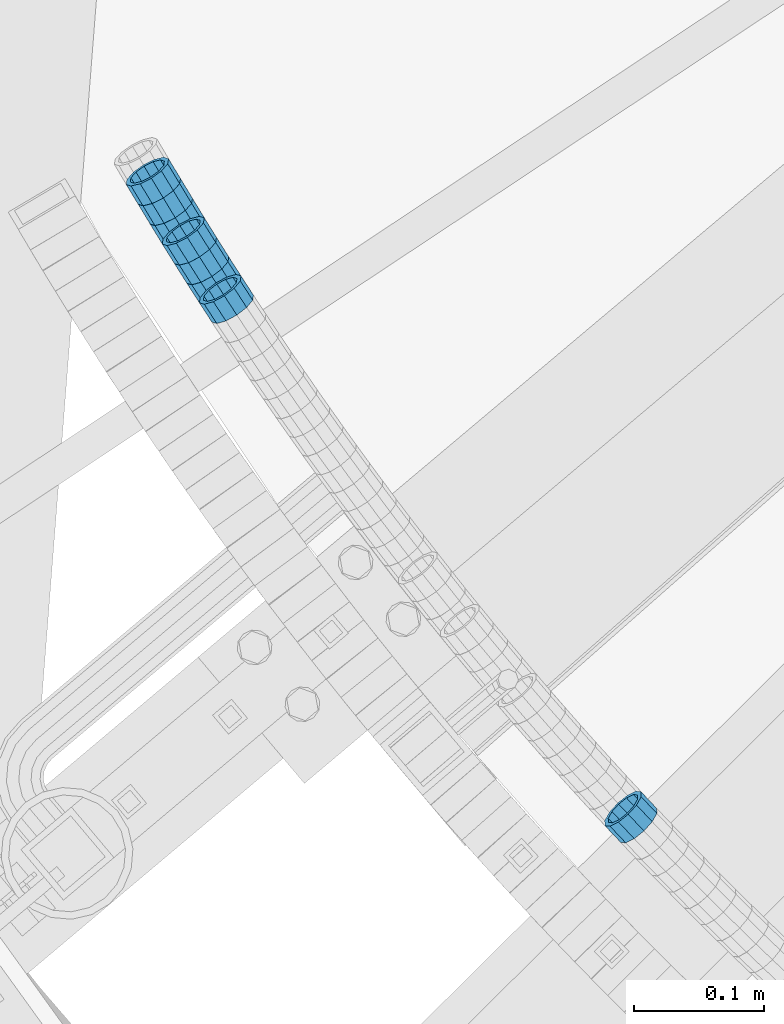
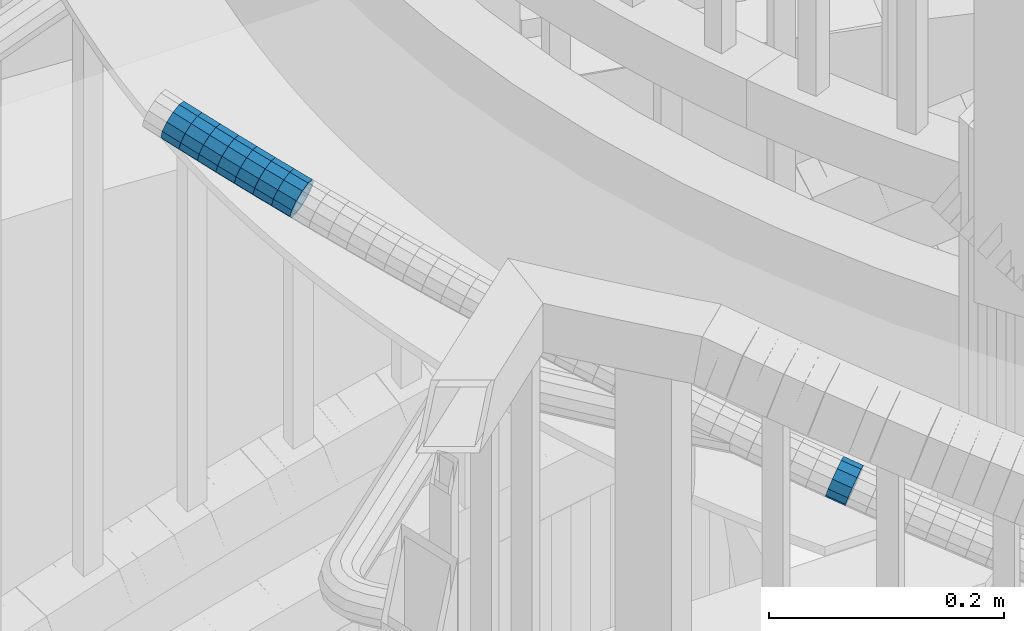
# One storey, part 655 of 975: 8 beams.
"""IFC2X3 building model written with IfcOpenShell, lengths in millimetres."""

from ifc_helpers import new_model, si_unit, frame, origin_with_axes, place, context, subcontext, project, spatial, faceted_brep, material, type_object, element, save


model = new_model("IFC2X3")

# Units and contexts
model_context = context("Model", 3, precision=1e-05, world=origin_with_axes())
body_context = subcontext(model_context, "Body", "Model", "MODEL_VIEW")
ifc_project = project(units=[si_unit("LENGTHUNIT", "METRE", prefix="MILLI"), si_unit("AREAUNIT", "SQUARE_METRE"), si_unit("VOLUMEUNIT", "CUBIC_METRE"), si_unit("MASSUNIT", "GRAM", prefix="KILO"), si_unit("TIMEUNIT", "SECOND"), si_unit("PLANEANGLEUNIT", "RADIAN"), si_unit("SOLIDANGLEUNIT", "STERADIAN"), si_unit("THERMODYNAMICTEMPERATUREUNIT", "DEGREE_CELSIUS"), si_unit("LUMINOUSINTENSITYUNIT", "LUMEN")], contexts=[model_context])

# Site, building, storey
site_placement = place(None, origin_with_axes())
site = spatial("IfcSite", under=ifc_project, at=site_placement, CompositionType="ELEMENT")
building_placement = place(site_placement, origin_with_axes())
building = spatial("IfcBuilding", under=site, at=building_placement, Name="Undefined", CompositionType="ELEMENT")
storey_placement = place(building_placement, origin_with_axes())
storey = spatial("IfcBuildingStorey", under=building, at=storey_placement, Name="Undefined", CompositionType="ELEMENT", Elevation=0.0)

# Beams
ifc_material = material()
beam_type = type_object("IfcBeamType", PredefinedType="NOTDEFINED")
beam_1_placement = place(storey_placement, frame((32387.4586977455, 1899.99917877906, 5122.80302633104), z_axis=(0.838961287171916, 0.544191104876625, -6.47896740701979e-11), x_axis=(0.516966515925029, -0.796990045884351, -0.312333936954659)))
element("IfcBeam", 1, at=beam_1_placement, inside=storey, type_object=beam_type, material=ifc_material, Name="WALL", context=body_context, shape_type="Brep", body=[
    faceted_brep([(-2.1246523829177e-07, -15.367000000002, 0.0), (-1.83998054126278e-07, -13.3082123799541, 7.68350000000009), (18.5698680663245, -13.3082123799541, 7.68350000001374), (18.569868066319, -15.3669999999947, 7.27595761418343e-12), (-1.06232619145885e-07, -7.68349999999919, 13.3082123799559), (18.5698680663281, -7.68350000000282, 13.3082123799759), (-3.63797880709171e-12, 3.63797880709171e-12, 15.3670000000002), (18.5698680663318, -3.63797880709171e-12, 15.3670000000275), (1.06225343188271e-07, 7.68350000000646, 13.3082123799559), (18.5698680663354, 7.68349999999555, 13.3082123799904), (1.8399441614747e-07, 13.308212379965, 7.68350000000009), (18.5698680663409, 13.3082123799522, 7.68350000003193), (2.12461600312963e-07, 15.3670000000093, 0.0), (18.569868066339, 15.3669999999966, 3.63797880709171e-11), (1.8399441614747e-07, 13.308212379965, -7.68350000000009), (18.5698680663336, 13.3082123799541, -7.68349999997008), (1.06225343188271e-07, 7.68350000000646, -13.3082123799559), (18.5698680663281, 7.68350000000282, -13.3082123799322), (-3.63797880709171e-12, 3.63797880709171e-12, -15.3670000000002), (18.5698680663263, 7.27595761418343e-12, -15.3669999999838), (-1.06232619145885e-07, -7.68349999999919, -13.3082123799559), (18.569868066319, -7.68349999999191, -13.3082123799468), (-1.83998054126278e-07, -13.3082123799541, -7.68350000000009), (18.5698680663172, -13.3082123799486, -7.68349999998827), (-2.63386027654633e-07, -19.0500000000029, 0.0), (-2.28097633225843e-07, -16.4977839420972, -9.52499999999964), (18.5698680663154, -16.4977839420862, -9.52499999999782), (18.5698680663154, -19.0499999999956, 7.27595761418343e-12), (-1.31691194837913e-07, -9.52500000000146, -16.4977839420935), (18.569868066319, -9.52499999999054, -16.4977839420862), (-3.63797880709171e-12, 3.63797880709171e-12, -19.0500000000002), (18.5698680663245, 7.27595761418343e-12, -19.0499999999847), (1.31687556859106e-07, 9.52500000000509, -16.4977839420935), (18.5698680663299, 9.52500000000509, -16.4977839420717), (2.28097633225843e-07, 16.4977839421044, -9.52499999999964), (18.5698680663372, 16.4977839420935, -9.52499999996871), (2.63382389675826e-07, 19.0500000000138, 0.0), (18.5698680663427, 19.0499999999956, 3.63797880709171e-11), (2.28097633225843e-07, 16.4977839421044, 9.52499999999964), (18.5698680663427, 16.4977839420899, 9.52500000004147), (1.31687556859106e-07, 9.52500000000509, 16.4977839420935), (18.569868066339, 9.52499999999418, 16.4977839421299), (-3.63797880709171e-12, 3.63797880709171e-12, 19.0500000000002), (18.5698680663336, -5.45696821063757e-12, 19.0500000000284), (-1.31691194837913e-07, -9.52500000000146, 16.4977839420935), (18.5698680663281, -9.52500000000146, 16.4977839421117), (-2.28097633225843e-07, -16.4977839420972, 9.52499999999964), (18.5698680663209, -16.4977839420917, 9.52500000001237)], [[[0, 1, 2, 3]], [[1, 4, 5, 2]], [[4, 6, 7, 5]], [[6, 8, 9, 7]], [[8, 10, 11, 9]], [[10, 12, 13, 11]], [[12, 14, 15, 13]], [[14, 16, 17, 15]], [[16, 18, 19, 17]], [[18, 20, 21, 19]], [[20, 22, 23, 21]], [[22, 0, 3, 23]], [[24, 25, 26, 27]], [[25, 28, 29, 26]], [[28, 30, 31, 29]], [[30, 32, 33, 31]], [[32, 34, 35, 33]], [[34, 36, 37, 35]], [[36, 38, 39, 37]], [[38, 40, 41, 39]], [[40, 42, 43, 41]], [[42, 44, 45, 43]], [[44, 46, 47, 45]], [[46, 24, 27, 47]], [[29, 31, 33, 35, 37, 39, 41, 43, 45, 47, 27, 26], [5, 7, 9, 11, 13, 15, 17, 19, 21, 23, 3, 2]], [[46, 44, 42, 40, 38, 36, 34, 32, 30, 28, 25, 24], [22, 20, 18, 16, 14, 12, 10, 8, 6, 4, 1, 0]]]),
])
beam_2_placement = place(storey_placement, frame((32368.4316061719, 1929.90477199626, 5134.3916756301), z_axis=(0.844819075603214, 0.535052081107, 9.88802639767529e-11), x_axis=(0.508603499889652, -0.803058157825771, -0.310515820932648)))
element("IfcBeam", 2, at=beam_2_placement, inside=storey, type_object=beam_type, material=ifc_material, Name="WALL", context=body_context, shape_type="Brep", body=[
    faceted_brep([(-2.1246523829177e-07, -15.367000000002, 0.0), (-1.83998054126278e-07, -13.3082123799541, 7.68350000000009), (18.6785973777551, -13.3082123799559, 7.68350000000282), (18.6785973777623, -15.3670000000002, 1.09139364212751e-11), (-1.06232619145885e-07, -7.68349999999919, 13.3082123799559), (18.6785973777532, -7.68350000000282, 13.3082123799541), (-3.63797880709171e-12, 3.63797880709171e-12, 15.3670000000002), (18.6785973777514, 0.0, 15.3669999999947), (1.06225343188271e-07, 7.68350000000646, 13.3082123799559), (18.678597377746, 7.68349999999919, 13.3082123799468), (1.8399441614747e-07, 13.308212379965, 7.68350000000009), (18.6785973777496, 13.3082123799541, 7.68349999999191), (2.12461600312963e-07, 15.3670000000093, 0.0), (18.6785973777514, 15.3670000000002, -3.63797880709171e-12), (1.8399441614747e-07, 13.308212379965, -7.68350000000009), (18.6785973777551, 13.3082123799577, -7.68349999999919), (1.06225343188271e-07, 7.68350000000646, -13.3082123799559), (18.6785973777605, 7.683500000001, -13.3082123799504), (-3.63797880709171e-12, 3.63797880709171e-12, -15.3670000000002), (18.6785973777642, 1.81898940354586e-12, -15.3669999999875), (-1.06232619145885e-07, -7.68349999999919, -13.3082123799559), (18.678597377766, -7.68349999999919, -13.3082123799431), (-1.83998054126278e-07, -13.3082123799541, -7.68350000000009), (18.6785973777605, -13.3082123799541, -7.68349999998827), (-2.63386027654633e-07, -19.0500000000029, 0.0), (-2.28097633225843e-07, -16.4977839420972, -9.52499999999964), (18.678597377766, -16.4977839420935, -9.52499999998327), (18.6785973777605, -19.0499999999993, 1.45519152283669e-11), (-1.31691194837913e-07, -9.52500000000146, -16.4977839420935), (18.6785973777678, -9.52499999999782, -16.497783942079), (-3.63797880709171e-12, 3.63797880709171e-12, -19.0500000000002), (18.678597377766, 3.63797880709171e-12, -19.0499999999884), (1.31687556859106e-07, 9.52500000000509, -16.4977839420935), (18.6785973777623, 9.52500000000146, -16.4977839420862), (2.28097633225843e-07, 16.4977839421044, -9.52499999999964), (18.6785973777551, 16.4977839420935, -9.52499999999782), (2.63382389675826e-07, 19.0500000000138, 0.0), (18.6785973777496, 19.0499999999993, -7.27595761418343e-12), (2.28097633225843e-07, 16.4977839421044, 9.52499999999964), (18.6785973777478, 16.4977839420935, 9.52499999999054), (1.31687556859106e-07, 9.52500000000509, 16.4977839420935), (18.678597377746, 9.52499999999782, 16.4977839420862), (-3.63797880709171e-12, 3.63797880709171e-12, 19.0500000000002), (18.6785973777442, -1.81898940354586e-12, 19.049999999992), (-1.31691194837913e-07, -9.52500000000146, 16.4977839420935), (18.6785973777514, -9.52500000000146, 16.4977839420972), (-2.28097633225843e-07, -16.4977839420972, 9.52499999999964), (18.6785973777551, -16.4977839420935, 9.52500000000509)], [[[0, 1, 2, 3]], [[1, 4, 5, 2]], [[4, 6, 7, 5]], [[6, 8, 9, 7]], [[8, 10, 11, 9]], [[10, 12, 13, 11]], [[12, 14, 15, 13]], [[14, 16, 17, 15]], [[16, 18, 19, 17]], [[18, 20, 21, 19]], [[20, 22, 23, 21]], [[22, 0, 3, 23]], [[24, 25, 26, 27]], [[25, 28, 29, 26]], [[28, 30, 31, 29]], [[30, 32, 33, 31]], [[32, 34, 35, 33]], [[34, 36, 37, 35]], [[36, 38, 39, 37]], [[38, 40, 41, 39]], [[40, 42, 43, 41]], [[42, 44, 45, 43]], [[44, 46, 47, 45]], [[46, 24, 27, 47]], [[29, 31, 33, 35, 37, 39, 41, 43, 45, 47, 27, 26], [5, 7, 9, 11, 13, 15, 17, 19, 21, 23, 3, 2]], [[46, 44, 42, 40, 38, 36, 34, 32, 30, 28, 25, 24], [22, 20, 18, 16, 14, 12, 10, 8, 6, 4, 1, 0]]]),
])
beam_3_placement = place(storey_placement, frame((32331.3879521192, 1990.64344126939, 5157.72073807088), z_axis=(0.85550007890286, 0.517802679596389, 1.8612809071783e-10), x_axis=(0.491416813934311, -0.811906039891549, -0.315147738957896)))
element("IfcBeam", 3, at=beam_3_placement, inside=storey, type_object=beam_type, material=ifc_material, Name="WALL", context=body_context, shape_type="Brep", body=[
    faceted_brep([(-2.1246523829177e-07, -15.367000000002, 0.0), (-1.83998054126278e-07, -13.3082123799541, 7.68350000000009), (18.7213781543887, -13.3082123799431, 7.68349999997372), (18.7213781543924, -15.3669999999856, -2.18278728425503e-11), (-1.06232619145885e-07, -7.68349999999919, 13.3082123799559), (18.7213781543869, -7.68349999999009, 13.308212379925), (-3.63797880709171e-12, 3.63797880709171e-12, 15.3670000000002), (18.7213781543869, 9.09494701772928e-12, 15.3669999999693), (1.06225343188271e-07, 7.68350000000646, 13.3082123799559), (18.7213781543905, 7.68350000000828, 13.3082123799286), (1.8399441614747e-07, 13.308212379965, 7.68350000000009), (18.7213781543942, 13.3082123799632, 7.683499999981), (2.12461600312963e-07, 15.3670000000093, 0.0), (18.7213781543978, 15.3670000000111, -1.81898940354586e-11), (1.8399441614747e-07, 13.308212379965, -7.68350000000009), (18.7213781544015, 13.3082123799668, -7.68350000000646), (1.06225343188271e-07, 7.68350000000646, -13.3082123799559), (18.7213781544033, 7.68350000001192, -13.3082123799613), (-3.63797880709171e-12, 3.63797880709171e-12, -15.3670000000002), (18.7213781544015, 1.63709046319127e-11, -15.3670000000093), (-1.06232619145885e-07, -7.68349999999919, -13.3082123799559), (18.7213781544015, -7.68349999998645, -13.308212379965), (-1.83998054126278e-07, -13.3082123799541, -7.68350000000009), (18.7213781543942, -13.3082123799413, -7.68350000001374), (-2.63386027654633e-07, -19.0500000000029, 0.0), (-2.28097633225843e-07, -16.4977839420972, -9.52499999999964), (18.721378154396, -16.4977839420771, -9.52500000001237), (18.7213781543905, -19.0499999999865, -2.18278728425503e-11), (-1.31691194837913e-07, -9.52500000000146, -16.4977839420935), (18.7213781544015, -9.52499999998508, -16.4977839421008), (-3.63797880709171e-12, 3.63797880709171e-12, -19.0500000000002), (18.7213781544033, 1.45519152283669e-11, -19.0500000000065), (1.31687556859106e-07, 9.52500000000509, -16.4977839420935), (18.7213781544051, 9.52500000001419, -16.4977839420935), (2.28097633225843e-07, 16.4977839421044, -9.52499999999964), (18.7213781544033, 16.4977839421063, -9.52500000000873), (2.63382389675826e-07, 19.0500000000138, 0.0), (18.7213781543978, 19.0500000000102, -1.45519152283669e-11), (2.28097633225843e-07, 16.4977839421044, 9.52499999999964), (18.7213781543942, 16.4977839421026, 9.52499999997599), (1.31687556859106e-07, 9.52500000000509, 16.4977839420935), (18.7213781543887, 9.52500000000691, 16.4977839420644), (-3.63797880709171e-12, 3.63797880709171e-12, 19.0500000000002), (18.7213781543833, 9.09494701772928e-12, 19.0499999999665), (-1.31691194837913e-07, -9.52500000000146, 16.4977839420935), (18.7213781543851, -9.52499999998872, 16.4977839420644), (-2.28097633225843e-07, -16.4977839420972, 9.52499999999964), (18.7213781543887, -16.4977839420808, 9.52499999997235)], [[[0, 1, 2, 3]], [[1, 4, 5, 2]], [[4, 6, 7, 5]], [[6, 8, 9, 7]], [[8, 10, 11, 9]], [[10, 12, 13, 11]], [[12, 14, 15, 13]], [[14, 16, 17, 15]], [[16, 18, 19, 17]], [[18, 20, 21, 19]], [[20, 22, 23, 21]], [[22, 0, 3, 23]], [[24, 25, 26, 27]], [[25, 28, 29, 26]], [[28, 30, 31, 29]], [[30, 32, 33, 31]], [[32, 34, 35, 33]], [[34, 36, 37, 35]], [[36, 38, 39, 37]], [[38, 40, 41, 39]], [[40, 42, 43, 41]], [[42, 44, 45, 43]], [[44, 46, 47, 45]], [[46, 24, 27, 47]], [[29, 31, 33, 35, 37, 39, 41, 43, 45, 47, 27, 26], [5, 7, 9, 11, 13, 15, 17, 19, 21, 23, 3, 2]], [[46, 44, 42, 40, 38, 36, 34, 32, 30, 28, 25, 24], [22, 20, 18, 16, 14, 12, 10, 8, 6, 4, 1, 0]]]),
])
beam_4_placement = place(storey_placement, frame((32340.6355277965, 1975.36483797635, 5151.79048636171), z_axis=(0.85550007890286, 0.517802679596389, 1.8612809071783e-10), x_axis=(0.492239092983619, -0.813264587972886, -0.310324644989658)))
element("IfcBeam", 4, at=beam_4_placement, inside=storey, type_object=beam_type, material=ifc_material, Name="WALL", context=body_context, shape_type="Brep", body=[
    faceted_brep([(-2.1246523829177e-07, -15.367000000002, 0.0), (-1.83998054126278e-07, -13.3082123799541, 7.68350000000009), (18.6901043335838, -13.3082123799413, 7.68349999999555), (18.6901043335874, -15.3669999999875, 3.63797880709171e-12), (-1.06232619145885e-07, -7.68349999999919, 13.3082123799559), (18.6901043335783, -7.68349999998281, 13.3082123799395), (-3.63797880709171e-12, 3.63797880709171e-12, 15.3670000000002), (18.6901043335693, 1.63709046319127e-11, 15.3669999999765), (1.06225343188271e-07, 7.68350000000646, 13.3082123799559), (18.690104333562, 7.68350000001556, 13.3082123799177), (1.8399441614747e-07, 13.308212379965, 7.68350000000009), (18.6901043335565, 13.3082123799668, 7.68349999995917), (2.12461600312963e-07, 15.3670000000093, 0.0), (18.6901043335565, 15.3670000000075, -4.36557456851006e-11), (1.8399441614747e-07, 13.308212379965, -7.68350000000009), (18.6901043335583, 13.3082123799613, -7.68350000003556), (1.06225343188271e-07, 7.68350000000646, -13.3082123799559), (18.6901043335656, 7.68350000000464, -13.3082123799868), (-3.63797880709171e-12, 3.63797880709171e-12, -15.3670000000002), (18.6901043335747, 5.45696821063757e-12, -15.3670000000129), (-1.06232619145885e-07, -7.68349999999919, -13.3082123799559), (18.6901043335802, -7.68349999999373, -13.3082123799577), (-1.83998054126278e-07, -13.3082123799541, -7.68350000000009), (18.6901043335856, -13.308212379945, -7.68349999999919), (-2.63386027654633e-07, -19.0500000000029, 0.0), (-2.28097633225843e-07, -16.4977839420972, -9.52499999999964), (18.6901043335874, -16.4977839420844, -9.52499999999418), (18.6901043335874, -19.0499999999865, 7.27595761418343e-12), (-1.31691194837913e-07, -9.52500000000146, -16.4977839420935), (18.6901043335838, -9.524999999996, -16.4977839420935), (-3.63797880709171e-12, 3.63797880709171e-12, -19.0500000000002), (18.6901043335747, 3.63797880709171e-12, -19.0500000000102), (1.31687556859106e-07, 9.52500000000509, -16.4977839420935), (18.6901043335656, 9.52500000000146, -16.497783942119), (2.28097633225843e-07, 16.4977839421044, -9.52499999999964), (18.6901043335583, 16.497783942099, -9.52500000003783), (2.63382389675826e-07, 19.0500000000138, 0.0), (18.6901043335547, 19.0500000000065, -4.72937244921923e-11), (2.28097633225843e-07, 16.4977839421044, 9.52499999999964), (18.6901043335547, 16.4977839421044, 9.52499999995416), (1.31687556859106e-07, 9.52500000000509, 16.4977839420935), (18.6901043335583, 9.52500000001419, 16.4977839420535), (-3.63797880709171e-12, 3.63797880709171e-12, 19.0500000000002), (18.6901043335693, 1.81898940354586e-11, 19.0499999999738), (-1.31691194837913e-07, -9.52500000000146, 16.4977839420935), (18.6901043335765, -9.52499999998145, 16.497783942079), (-2.28097633225843e-07, -16.4977839420972, 9.52499999999964), (18.6901043335856, -16.4977839420753, 9.52499999999782)], [[[0, 1, 2, 3]], [[1, 4, 5, 2]], [[4, 6, 7, 5]], [[6, 8, 9, 7]], [[8, 10, 11, 9]], [[10, 12, 13, 11]], [[12, 14, 15, 13]], [[14, 16, 17, 15]], [[16, 18, 19, 17]], [[18, 20, 21, 19]], [[20, 22, 23, 21]], [[22, 0, 3, 23]], [[24, 25, 26, 27]], [[25, 28, 29, 26]], [[28, 30, 31, 29]], [[30, 32, 33, 31]], [[32, 34, 35, 33]], [[34, 36, 37, 35]], [[36, 38, 39, 37]], [[38, 40, 41, 39]], [[40, 42, 43, 41]], [[42, 44, 45, 43]], [[44, 46, 47, 45]], [[46, 24, 27, 47]], [[29, 31, 33, 35, 37, 39, 41, 43, 45, 47, 27, 26], [5, 7, 9, 11, 13, 15, 17, 19, 21, 23, 3, 2]], [[46, 44, 42, 40, 38, 36, 34, 32, 30, 28, 25, 24], [22, 20, 18, 16, 14, 12, 10, 8, 6, 4, 1, 0]]]),
])
beam_5_placement = place(storey_placement, frame((32377.8878273931, 1914.88769543147, 5128.59467594494), z_axis=(0.840628117663209, 0.541612747074892, 8.02892827778124e-11), x_axis=(0.514754558153063, -0.798941970237571, -0.310997545092485)))
element("IfcBeam", 5, at=beam_5_placement, inside=storey, type_object=beam_type, material=ifc_material, Name="WALL", context=body_context, shape_type="Brep", body=[
    faceted_brep([(-2.1246523829177e-07, -15.367000000002, 0.0), (-1.83998054126278e-07, -13.3082123799541, 7.68350000000009), (18.6496648763459, -13.3082123799486, 7.68349999999191), (18.6496648763332, -15.3669999999911, -2.18278728425503e-11), (-1.06232619145885e-07, -7.68349999999919, 13.3082123799559), (18.649664876355, -7.68349999999555, 13.308212379965), (-3.63797880709171e-12, 3.63797880709171e-12, 15.3670000000002), (18.6496648763605, 0.0, 15.3670000000166), (1.06225343188271e-07, 7.68350000000646, 13.3082123799559), (18.6496648763641, 7.68349999999555, 13.3082123799795), (1.8399441614747e-07, 13.308212379965, 7.68350000000009), (18.6496648763623, 13.3082123799486, 7.68350000002829), (2.12461600312963e-07, 15.3670000000093, 0.0), (18.649664876355, 15.3669999999911, 1.81898940354586e-11), (1.8399441614747e-07, 13.308212379965, -7.68350000000009), (18.6496648763459, 13.3082123799486, -7.68349999999555), (1.06225343188271e-07, 7.68350000000646, -13.3082123799559), (18.6496648763368, 7.68349999999737, -13.308212379965), (-3.63797880709171e-12, 3.63797880709171e-12, -15.3670000000002), (18.6496648763314, 1.81898940354586e-12, -15.3670000000238), (-1.06232619145885e-07, -7.68349999999919, -13.3082123799559), (18.6496648763241, -7.68349999999373, -13.3082123799868), (-1.83998054126278e-07, -13.3082123799541, -7.68350000000009), (18.6496648763296, -13.3082123799468, -7.68350000003193), (-2.63386027654633e-07, -19.0500000000029, 0.0), (-2.28097633225843e-07, -16.4977839420972, -9.52499999999964), (18.6496648763223, -16.4977839420826, -9.52500000003783), (18.6496648763332, -19.0499999999902, -2.5465851649642e-11), (-1.31691194837913e-07, -9.52500000000146, -16.4977839420935), (18.6496648763223, -9.52499999999236, -16.4977839421299), (-3.63797880709171e-12, 3.63797880709171e-12, -19.0500000000002), (18.6496648763259, 1.81898940354586e-12, -19.0500000000284), (1.31687556859106e-07, 9.52500000000509, -16.4977839420935), (18.6496648763368, 9.524999999996, -16.4977839421044), (2.28097633225843e-07, 16.4977839421044, -9.52499999999964), (18.6496648763459, 16.4977839420844, -9.52499999999418), (2.63382389675826e-07, 19.0500000000138, 0.0), (18.6496648763587, 19.0499999999902, 2.5465851649642e-11), (2.28097633225843e-07, 16.4977839421044, 9.52499999999964), (18.6496648763641, 16.4977839420844, 9.52500000003056), (1.31687556859106e-07, 9.52500000000509, 16.4977839420935), (18.6496648763696, 9.52499999999418, 16.4977839421299), (-3.63797880709171e-12, 3.63797880709171e-12, 19.0500000000002), (18.6496648763623, -1.81898940354586e-12, 19.0500000000211), (-1.31691194837913e-07, -9.52500000000146, 16.4977839420935), (18.649664876355, -9.524999999996, 16.4977839421008), (-2.28097633225843e-07, -16.4977839420972, 9.52499999999964), (18.6496648763423, -16.4977839420844, 9.52499999999054)], [[[0, 1, 2, 3]], [[1, 4, 5, 2]], [[4, 6, 7, 5]], [[6, 8, 9, 7]], [[8, 10, 11, 9]], [[10, 12, 13, 11]], [[12, 14, 15, 13]], [[14, 16, 17, 15]], [[16, 18, 19, 17]], [[18, 20, 21, 19]], [[20, 22, 23, 21]], [[22, 0, 3, 23]], [[24, 25, 26, 27]], [[25, 28, 29, 26]], [[28, 30, 31, 29]], [[30, 32, 33, 31]], [[32, 34, 35, 33]], [[34, 36, 37, 35]], [[36, 38, 39, 37]], [[38, 40, 41, 39]], [[40, 42, 43, 41]], [[42, 44, 45, 43]], [[44, 46, 47, 45]], [[46, 24, 27, 47]], [[29, 31, 33, 35, 37, 39, 41, 43, 45, 47, 27, 26], [5, 7, 9, 11, 13, 15, 17, 19, 21, 23, 3, 2]], [[46, 44, 42, 40, 38, 36, 34, 32, 30, 28, 25, 24], [22, 20, 18, 16, 14, 12, 10, 8, 6, 4, 1, 0]]]),
])
beam_6_placement = place(storey_placement, frame((32359.0469492592, 1944.93345196954, 5140.19693876634), z_axis=(0.847362967363517, 0.531014125556839, -1.86284523806535e-10), x_axis=(0.504618438929444, -0.805242190887507, -0.311360313956512)))
element("IfcBeam", 6, at=beam_6_placement, inside=storey, type_object=beam_type, material=ifc_material, Name="WALL", context=body_context, shape_type="Brep", body=[
    faceted_brep([(-2.1246523829177e-07, -15.367000000002, 0.0), (-1.83998054126278e-07, -13.3082123799541, 7.68350000000009), (18.6279360102071, -13.3082123799559, 7.68349999999191), (18.6279360102035, -15.367000000002, -1.09139364212751e-11), (-1.06232619145885e-07, -7.68349999999919, 13.3082123799559), (18.6279360102071, -7.683500000001, 13.3082123799468), (-3.63797880709171e-12, 3.63797880709171e-12, 15.3670000000002), (18.6279360102035, 0.0, 15.3669999999875), (1.06225343188271e-07, 7.68350000000646, 13.3082123799559), (18.6279360101962, 7.68349999999919, 13.3082123799322), (1.8399441614747e-07, 13.308212379965, 7.68350000000009), (18.6279360101889, 13.3082123799559, 7.68349999996644), (2.12461600312963e-07, 15.3670000000093, 0.0), (18.6279360101817, 15.3670000000002, -4.36557456851006e-11), (1.8399441614747e-07, 13.308212379965, -7.68350000000009), (18.627936010178, 13.3082123799559, -7.68350000004648), (1.06225343188271e-07, 7.68350000000646, -13.3082123799559), (18.6279360101817, 7.68349999999919, -13.3082123800014), (-3.63797880709171e-12, 3.63797880709171e-12, -15.3670000000002), (18.6279360101853, 0.0, -15.3670000000384), (-1.06232619145885e-07, -7.68349999999919, -13.3082123799559), (18.6279360101926, -7.68349999999919, -13.3082123799795), (-1.83998054126278e-07, -13.3082123799541, -7.68350000000009), (18.6279360101998, -13.3082123799577, -7.68350000002101), (-2.63386027654633e-07, -19.0500000000029, 0.0), (-2.28097633225843e-07, -16.4977839420972, -9.52499999999964), (18.6279360102017, -16.4977839420953, -9.52500000001601), (18.6279360102089, -19.0500000000011, -7.27595761418343e-12), (-1.31691194837913e-07, -9.52500000000146, -16.4977839420935), (18.6279360101926, -9.52500000000146, -16.4977839421226), (-3.63797880709171e-12, 3.63797880709171e-12, -19.0500000000002), (18.6279360101817, 0.0, -19.0500000000393), (1.31687556859106e-07, 9.52500000000509, -16.4977839420935), (18.627936010178, 9.52499999999964, -16.4977839421445), (2.28097633225843e-07, 16.4977839421044, -9.52499999999964), (18.6279360101762, 16.4977839420953, -9.52500000005239), (2.63382389675826e-07, 19.0500000000138, 0.0), (18.6279360101798, 19.0500000000029, -4.72937244921923e-11), (2.28097633225843e-07, 16.4977839421044, 9.52499999999964), (18.6279360101871, 16.4977839420935, 9.52499999996508), (1.31687556859106e-07, 9.52500000000509, 16.4977839420935), (18.6279360101962, 9.52499999999964, 16.4977839420681), (-3.63797880709171e-12, 3.63797880709171e-12, 19.0500000000002), (18.6279360102035, 0.0, 19.0499999999884), (-1.31691194837913e-07, -9.52500000000146, 16.4977839420935), (18.6279360102108, -9.52500000000146, 16.4977839420899), (-2.28097633225843e-07, -16.4977839420972, 9.52499999999964), (18.6279360102126, -16.4977839420935, 9.52500000000146)], [[[0, 1, 2, 3]], [[1, 4, 5, 2]], [[4, 6, 7, 5]], [[6, 8, 9, 7]], [[8, 10, 11, 9]], [[10, 12, 13, 11]], [[12, 14, 15, 13]], [[14, 16, 17, 15]], [[16, 18, 19, 17]], [[18, 20, 21, 19]], [[20, 22, 23, 21]], [[22, 0, 3, 23]], [[24, 25, 26, 27]], [[25, 28, 29, 26]], [[28, 30, 31, 29]], [[30, 32, 33, 31]], [[32, 34, 35, 33]], [[34, 36, 37, 35]], [[36, 38, 39, 37]], [[38, 40, 41, 39]], [[40, 42, 43, 41]], [[42, 44, 45, 43]], [[44, 46, 47, 45]], [[46, 24, 27, 47]], [[29, 31, 33, 35, 37, 39, 41, 43, 45, 47, 27, 26], [5, 7, 9, 11, 13, 15, 17, 19, 21, 23, 3, 2]], [[46, 44, 42, 40, 38, 36, 34, 32, 30, 28, 25, 24], [22, 20, 18, 16, 14, 12, 10, 8, 6, 4, 1, 0]]]),
])
beam_7_placement = place(storey_placement, frame((32697.4036050976, 1500.33718582568, 4957.0057286008), z_axis=(0.726698183248535, 0.686956876712999, -1.24897269415669e-10), x_axis=(0.652492609356425, -0.690240115377099, -0.312765052170881)))
element("IfcBeam", 7, at=beam_7_placement, inside=storey, type_object=beam_type, material=ifc_material, Name="WALL", context=body_context, shape_type="Brep", body=[
    faceted_brep([(-2.1246523829177e-07, -15.367000000002, 0.0), (-1.83998054126278e-07, -13.3082123799541, 7.68350000000009), (18.5442713526427, -13.3082123799486, 7.68349999999555), (18.544271352639, -15.3669999999893, -1.81898940354586e-12), (-1.06232619145885e-07, -7.68349999999919, 13.3082123799559), (18.5442713526427, -7.68349999999373, 13.3082123799541), (-3.63797880709171e-12, 3.63797880709171e-12, 15.3670000000002), (18.5442713526354, 5.45696821063757e-12, 15.3669999999947), (1.06225343188271e-07, 7.68350000000646, 13.3082123799559), (18.5442713526245, 7.68350000001192, 13.3082123799468), (1.8399441614747e-07, 13.308212379965, 7.68350000000009), (18.5442713526172, 13.3082123799704, 7.68349999998827), (2.12461600312963e-07, 15.3670000000093, 0.0), (18.5442713526027, 15.3670000000202, -1.45519152283669e-11), (1.8399441614747e-07, 13.308212379965, -7.68350000000009), (18.5442713526027, 13.3082123799759, -7.68350000001556), (1.06225343188271e-07, 7.68350000000646, -13.3082123799559), (18.5442713526027, 7.68350000002283, -13.3082123799686), (-3.63797880709171e-12, 3.63797880709171e-12, -15.3670000000002), (18.5442713526063, 2.18278728425503e-11, -15.3670000000129), (-1.06232619145885e-07, -7.68349999999919, -13.3082123799559), (18.5442713526209, -7.68349999998281, -13.3082123799632), (-1.83998054126278e-07, -13.3082123799541, -7.68350000000009), (18.5442713526318, -13.3082123799395, -7.68350000000646), (-2.63386027654633e-07, -19.0500000000029, 0.0), (-2.28097633225843e-07, -16.4977839420972, -9.52499999999964), (18.5442713526354, -16.4977839420808, -9.52500000000691), (18.5442713526427, -19.0499999999902, -1.81898940354586e-12), (-1.31691194837913e-07, -9.52500000000146, -16.4977839420935), (18.5442713526245, -9.52499999997963, -16.4977839421044), (-3.63797880709171e-12, 3.63797880709171e-12, -19.0500000000002), (18.5442713526099, 2.36468622460961e-11, -19.0500000000138), (1.31687556859106e-07, 9.52500000000509, -16.4977839420935), (18.544271352599, 9.5250000000251, -16.4977839421081), (2.28097633225843e-07, 16.4977839421044, -9.52499999999964), (18.5442713525917, 16.4977839421172, -9.52500000001601), (2.63382389675826e-07, 19.0500000000138, 0.0), (18.544271352599, 19.0500000000211, -1.45519152283669e-11), (2.28097633225843e-07, 16.4977839421044, 9.52499999999964), (18.5442713526136, 16.4977839421099, 9.52499999998872), (1.31687556859106e-07, 9.52500000000509, 16.4977839420935), (18.5442713526281, 9.52500000000873, 16.4977839420862), (-3.63797880709171e-12, 3.63797880709171e-12, 19.0500000000002), (18.5442713526427, 3.63797880709171e-12, 19.0499999999975), (-1.31691194837913e-07, -9.52500000000146, 16.4977839420935), (18.54427135265, -9.524999999996, 16.4977839420935), (-2.28097633225843e-07, -16.4977839420972, 9.52499999999964), (18.54427135265, -16.4977839420899, 9.52499999999964)], [[[0, 1, 2, 3]], [[1, 4, 5, 2]], [[4, 6, 7, 5]], [[6, 8, 9, 7]], [[8, 10, 11, 9]], [[10, 12, 13, 11]], [[12, 14, 15, 13]], [[14, 16, 17, 15]], [[16, 18, 19, 17]], [[18, 20, 21, 19]], [[20, 22, 23, 21]], [[22, 0, 3, 23]], [[24, 25, 26, 27]], [[25, 28, 29, 26]], [[28, 30, 31, 29]], [[30, 32, 33, 31]], [[32, 34, 35, 33]], [[34, 36, 37, 35]], [[36, 38, 39, 37]], [[38, 40, 41, 39]], [[40, 42, 43, 41]], [[42, 44, 45, 43]], [[44, 46, 47, 45]], [[46, 24, 27, 47]], [[29, 31, 33, 35, 37, 39, 41, 43, 45, 47, 27, 26], [5, 7, 9, 11, 13, 15, 17, 19, 21, 23, 3, 2]], [[46, 44, 42, 40, 38, 36, 34, 32, 30, 28, 25, 24], [22, 20, 18, 16, 14, 12, 10, 8, 6, 4, 1, 0]]]),
])
beam_8_placement = place(storey_placement, frame((32349.8194201537, 1960.1367833007, 5145.98540384171), z_axis=(0.853004272179022, 0.521903929516091, -1.64764969667885e-10), x_axis=(0.496277110072505, -0.811119578118542, -0.309506155045229)))
element("IfcBeam", 8, at=beam_8_placement, inside=storey, type_object=beam_type, material=ifc_material, Name="WALL", context=body_context, shape_type="Brep", body=[
    faceted_brep([(-2.1246523829177e-07, -15.367000000002, 0.0), (-1.83998054126278e-07, -13.3082123799541, 7.68350000000009), (18.7395304103302, -13.3082123799504, 7.68350000005739), (18.7395304103338, -15.3669999999975, 4.36557456851006e-11), (-1.06232619145885e-07, -7.68349999999919, 13.3082123799559), (18.7395304103266, -7.68349999999191, 13.3082123800268), (-3.63797880709171e-12, 3.63797880709171e-12, 15.3670000000002), (18.7395304103284, 9.09494701772928e-12, 15.3670000000566), (1.06225343188271e-07, 7.68350000000646, 13.3082123799559), (18.7395304103284, 7.68350000000828, 13.308212380005), (1.8399441614747e-07, 13.308212379965, 7.68350000000009), (18.7395304103375, 13.3082123799613, 7.68350000002829), (2.12461600312963e-07, 15.3670000000093, 0.0), (18.7395304103429, 15.3670000000038, 1.45519152283669e-11), (1.8399441614747e-07, 13.308212379965, -7.68350000000009), (18.7395304103466, 13.3082123799559, -7.68350000000646), (1.06225343188271e-07, 7.68350000000646, -13.3082123799559), (18.7395304103484, 7.68349999999737, -13.3082123799686), (-3.63797880709171e-12, 3.63797880709171e-12, -15.3670000000002), (18.7395304103484, -3.63797880709171e-12, -15.3670000000129), (-1.06232619145885e-07, -7.68349999999919, -13.3082123799559), (18.7395304103466, -7.68350000000282, -13.3082123799541), (-1.83998054126278e-07, -13.3082123799541, -7.68350000000009), (18.7395304103411, -13.3082123799568, -7.68349999998463), (-2.63386027654633e-07, -19.0500000000029, 0.0), (-2.28097633225843e-07, -16.4977839420972, -9.52499999999964), (18.7395304103411, -16.4977839420953, -9.52499999997963), (18.7395304103356, -19.0499999999993, 4.36557456851006e-11), (-1.31691194837913e-07, -9.52500000000146, -16.4977839420935), (18.7395304103484, -9.52500000000509, -16.4977839420972), (-3.63797880709171e-12, 3.63797880709171e-12, -19.0500000000002), (18.7395304103557, -5.45696821063757e-12, -19.0500000000247), (1.31687556859106e-07, 9.52500000000509, -16.4977839420935), (18.739530410352, 9.52499999999691, -16.4977839421117), (2.28097633225843e-07, 16.4977839421044, -9.52499999999964), (18.7395304103484, 16.4977839420935, -9.52500000000146), (2.63382389675826e-07, 19.0500000000138, 0.0), (18.7395304103429, 19.0500000000029, 1.45519152283669e-11), (2.28097633225843e-07, 16.4977839421044, 9.52499999999964), (18.7395304103338, 16.4977839421008, 9.52500000003783), (1.31687556859106e-07, 9.52500000000509, 16.4977839420935), (18.7395304103302, 9.52500000000873, 16.4977839421481), (-3.63797880709171e-12, 3.63797880709171e-12, 19.0500000000002), (18.7395304103247, 1.09139364212751e-11, 19.0500000000684), (-1.31691194837913e-07, -9.52500000000146, 16.4977839420935), (18.7395304103247, -9.52499999999054, 16.4977839421699), (-2.28097633225843e-07, -16.4977839420972, 9.52499999999964), (18.7395304103284, -16.4977839420881, 9.52500000006694)], [[[0, 1, 2, 3]], [[1, 4, 5, 2]], [[4, 6, 7, 5]], [[6, 8, 9, 7]], [[8, 10, 11, 9]], [[10, 12, 13, 11]], [[12, 14, 15, 13]], [[14, 16, 17, 15]], [[16, 18, 19, 17]], [[18, 20, 21, 19]], [[20, 22, 23, 21]], [[22, 0, 3, 23]], [[24, 25, 26, 27]], [[25, 28, 29, 26]], [[28, 30, 31, 29]], [[30, 32, 33, 31]], [[32, 34, 35, 33]], [[34, 36, 37, 35]], [[36, 38, 39, 37]], [[38, 40, 41, 39]], [[40, 42, 43, 41]], [[42, 44, 45, 43]], [[44, 46, 47, 45]], [[46, 24, 27, 47]], [[29, 31, 33, 35, 37, 39, 41, 43, 45, 47, 27, 26], [5, 7, 9, 11, 13, 15, 17, 19, 21, 23, 3, 2]], [[46, 44, 42, 40, 38, 36, 34, 32, 30, 28, 25, 24], [22, 20, 18, 16, 14, 12, 10, 8, 6, 4, 1, 0]]]),
])

save(model, "model.ifc")
